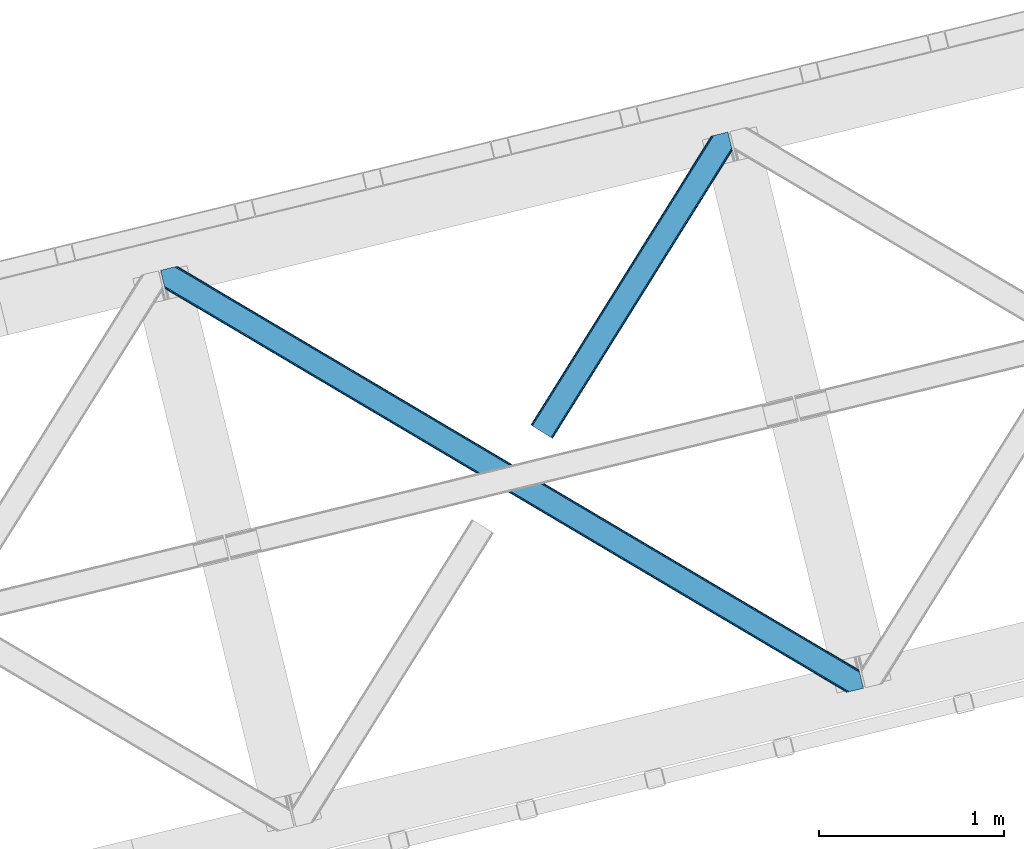
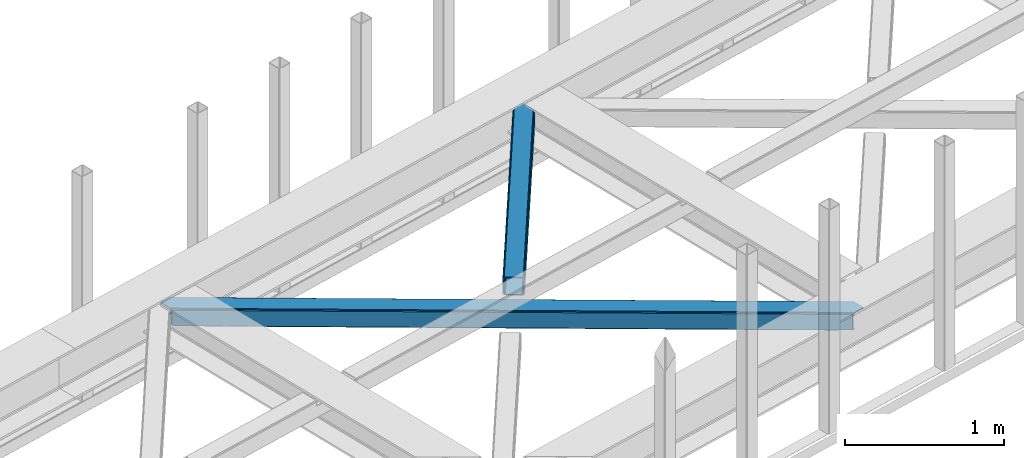
# One storey, part 45 of 66: 2 members.
"""IFC4 building model written with IfcOpenShell, lengths in millimetres."""

from ifc_helpers import new_model, entity, si_unit, converted_unit, derived_unit, direction, frame, origin, place, context, subcontext, project, spatial, triangles, type_object, element, save


model = new_model("IFC4")

# Units and contexts
model_context = context("Model", 3, precision=0.01, world=origin(), true_north=direction((6.12303176911189e-17, 1.0)))
plan_context = context("Plan", 3, precision=0.01, world=origin(), true_north=direction((6.12303176911189e-17, 1.0)))
body_context = subcontext(model_context, "Body", "Model", "MODEL_VIEW")
ifc_project = project(units=[si_unit("LENGTHUNIT", "METRE", prefix="MILLI"), si_unit("AREAUNIT", "SQUARE_METRE"), si_unit("VOLUMEUNIT", "CUBIC_METRE"), converted_unit("PLANEANGLEUNIT", "DEGREE", entity("IfcRatioMeasure", 0.0174532925199433), si_unit("PLANEANGLEUNIT", "RADIAN"), dimensions=[0, 0, 0, 0, 0, 0, 0]), si_unit("MASSUNIT", "GRAM", prefix="KILO"), derived_unit("MASSDENSITYUNIT", [(si_unit("MASSUNIT", "GRAM", prefix="KILO"), 1), (si_unit("LENGTHUNIT", "METRE"), -3)]), derived_unit("MOMENTOFINERTIAUNIT", [(si_unit("LENGTHUNIT", "METRE"), 4)]), si_unit("TIMEUNIT", "SECOND"), si_unit("FREQUENCYUNIT", "HERTZ"), si_unit("THERMODYNAMICTEMPERATUREUNIT", "DEGREE_CELSIUS"), derived_unit("THERMALTRANSMITTANCEUNIT", [(si_unit("MASSUNIT", "GRAM", prefix="KILO"), 1), (si_unit("THERMODYNAMICTEMPERATUREUNIT", "KELVIN"), -1), (si_unit("TIMEUNIT", "SECOND"), -3)]), derived_unit("VOLUMETRICFLOWRATEUNIT", [(si_unit("LENGTHUNIT", "METRE"), 3), (si_unit("TIMEUNIT", "SECOND"), -1)]), derived_unit("MASSFLOWRATEUNIT", [(si_unit("MASSUNIT", "GRAM", prefix="KILO"), 1), (si_unit("TIMEUNIT", "SECOND"), -1)]), derived_unit("ROTATIONALFREQUENCYUNIT", [(si_unit("TIMEUNIT", "SECOND"), -1)]), si_unit("ELECTRICCURRENTUNIT", "AMPERE"), si_unit("ELECTRICVOLTAGEUNIT", "VOLT"), si_unit("POWERUNIT", "WATT"), si_unit("FORCEUNIT", "NEWTON", prefix="KILO"), si_unit("ILLUMINANCEUNIT", "LUX"), si_unit("LUMINOUSFLUXUNIT", "LUMEN"), si_unit("LUMINOUSINTENSITYUNIT", "CANDELA"), derived_unit("USERDEFINED", [(si_unit("MASSUNIT", "GRAM", prefix="KILO"), -1), (si_unit("LENGTHUNIT", "METRE"), -2), (si_unit("TIMEUNIT", "SECOND"), 3), (si_unit("LUMINOUSFLUXUNIT", "LUMEN"), 1)]), derived_unit("LINEARVELOCITYUNIT", [(si_unit("LENGTHUNIT", "METRE"), 1), (si_unit("TIMEUNIT", "SECOND"), -1)]), si_unit("PRESSUREUNIT", "PASCAL"), derived_unit("USERDEFINED", [(si_unit("LENGTHUNIT", "METRE"), -2), (si_unit("MASSUNIT", "GRAM", prefix="KILO"), 1), (si_unit("TIMEUNIT", "SECOND"), -2)]), derived_unit("LINEARFORCEUNIT", [(si_unit("MASSUNIT", "GRAM", prefix="KILO"), 1), (si_unit("LENGTHUNIT", "METRE"), 1), (si_unit("TIMEUNIT", "SECOND"), -2), (si_unit("LENGTHUNIT", "METRE"), -1)]), derived_unit("PLANARFORCEUNIT", [(si_unit("MASSUNIT", "GRAM", prefix="KILO"), 1), (si_unit("LENGTHUNIT", "METRE"), 1), (si_unit("TIMEUNIT", "SECOND"), -2), (si_unit("LENGTHUNIT", "METRE"), -2)])], contexts=[model_context, plan_context])

# Site, building, storey
site_placement = place(None, origin())
site = spatial("IfcSite", under=ifc_project, at=site_placement, CompositionType="ELEMENT")
building_placement = place(site_placement, origin())
building = spatial("IfcBuilding", under=site, at=building_placement, CompositionType="ELEMENT")
storey_placement = place(building_placement, frame((0.0, 0.0, 19800.0)))
storey = spatial("IfcBuildingStorey", under=building, at=storey_placement, Name="06", CompositionType="ELEMENT", Elevation=19800.0)

# Members
member_type_1 = type_object("IfcMemberType", PredefinedType="BRACE")
member_1_placement = place(storey_placement, frame((-18949.85, 14772.6, 3823.0)))
element("IfcMember", 1, at=member_1_placement, inside=storey, type_object=member_type_1, ObjectType="Steel Horizontal Brace", PredefinedType="BRACE", context=body_context, shape_type="Tessellation", body=[
    triangles([(933.016305541994, 1535.69114685059, 0.0), (967.77581176758, 1393.09054870606, 0.0), (14.8444427490249, 64.8692962646492, 0.0), (103.913424682618, 9.26687622070313, 0.0), (928.799121093751, 1552.99009094238, 5.49966430664063), (928.938647460938, 1552.41570739746, 5.208984375), (930.798999023438, 1544.78594055176, 1.33247680664135), (971.99299621582, 1375.79160461426, 5.49966430664063), (971.852307128906, 1376.36715087891, 5.208984375), (969.993118286133, 1383.99575500488, 1.33247680664135), (972.208099365234, 1375.53813171387, 5.8531311035149), (972.418551635743, 1375.28233337402, 6.20659790039281), (928.911904907229, 1553.56912536621, 5.74383544921875), (972.720858764649, 1375.53696899414, 6.35310058593677), (929.027014160158, 1554.17606506348, 5.9996337890625), (973.022003173828, 1375.79160461426, 6.49960327148438), (929.142123413087, 1554.78300476074, 6.25543212890625), (929.250256347656, 1555.36203918457, 6.49960327148438), (4.34740905761646, 71.4223846435561, 5.12526855468968), (1.13016357422021, 73.4315643310547, 10.8039916992202), (973.355703735353, 1630.84231567383, 10.8039916992202), (976.91130065918, 1631.70854187012, 6.49960327148438), (9.16455688476708, 68.4167541503921, 1.33247680664135), (971.503491210937, 1630.3900177002, 17.5012573242202), (0.0, 74.1373352050796, 17.5012573242202), (1081.09680175781, 1548.91592102051, 6.49960327148438), (1056.20297241211, 1651.03759460449, 6.49960327148438), (971.503491210937, 1630.3900177002, 122.499499511719), (0.0, 74.1373352050796, 122.499499511719), (973.355703735353, 1630.84231567383, 129.196765136719), (1.13016357422021, 73.4315643310547, 129.196765136719), (978.633288574219, 1632.12828369141, 134.87548828125), (4.34740905761646, 71.4223846435561, 134.87548828125), (986.526992797852, 1634.05258483887, 138.668280029298), (9.16455688476708, 68.4167541503921, 138.668280029298), (995.835726928712, 1636.32221374512, 140.00075683594), (14.8444427490249, 64.8692962646492, 140.00075683594), (118.757867431643, 0.0, 17.5012573242202), (117.62886657715, 0.705770874024893, 10.8039916992202), (1085.13725280762, 1551.24949951172, 10.9783996582046), (1087.41153259277, 1552.56337280274, 13.4991760253906), (109.594473266603, 5.7205810546875, 1.33247680664135), (114.410458374023, 2.71495056152344, 5.12526855468968), (1087.56501159668, 1551.93434143066, 17.5012573242202), (1081.77234191895, 1575.70149536133, 140.00075683594), (1063.00372009277, 1652.69447021484, 140.00075683594), (103.913424682618, 9.26687622070313, 140.00075683594), (1083.9896484375, 1566.60553894043, 138.668280029298), (109.594473266603, 5.7205810546875, 138.668280029298), (1085.86860351562, 1558.8955444336, 134.87548828125), (114.410458374023, 2.71495056152344, 134.87548828125), (1087.12434082031, 1553.7435333252, 129.196765136719), (117.62886657715, 0.705770874024893, 129.196765136719), (1087.56501159668, 1551.93434143066, 122.499499511719), (118.757867431643, 0.0, 122.499499511719), (1082.5362487793, 1566.77297058106, 12.1248413085959), (1083.96058044434, 1566.72297363281, 13.4991760253906), (1077.84700012207, 1569.98440246582, 8.3320495605476), (1074.64603271485, 1577.50138549805, 6.99957275390625), (1056.69131469727, 1651.1561920166, 6.99957275390625), (1005.56885375977, 1638.69416198731, 6.99957275390625), (20.7789642333992, 61.1625457763676, 6.99957275390625), (97.9742523193381, 12.9736267089847, 6.99957275390625), (108.471286010743, 6.42053833007958, 12.1248413085959), (111.689694213866, 4.41252136230469, 17.8035644531265), (1084.80704040527, 1563.24992980957, 17.8035644531265), (103.65530090332, 9.42733154296911, 8.3320495605476), (1085.24771118164, 1561.44073791504, 24.5008300781265), (112.818695068359, 3.70675048828161, 24.5008300781265), (983.088830566408, 1633.21426391602, 17.8035644531265), (981.235455322265, 1632.76312866211, 24.5008300781265), (7.06468505859448, 69.7236511230476, 17.8035644531265), (5.93568420410156, 70.4294219970707, 24.5008300781265), (988.366415405275, 1634.50139465332, 12.1248413085959), (10.283093261718, 67.7144714355472, 12.1248413085959), (996.260119628907, 1636.42569580078, 8.3320495605476), (15.0990783691414, 64.7088409423832, 8.3320495605476), (981.235455322265, 1632.76312866211, 115.499926757813), (5.93568420410156, 70.4294219970707, 115.499926757813), (996.260119628907, 1636.42569580078, 131.668707275392), (1005.56885375977, 1638.69416198731, 133.001184082033), (1063.00372009277, 1652.69447021484, 133.001184082033), (988.366415405275, 1634.50139465332, 127.873590087893), (983.088830566408, 1633.21426391602, 122.197192382813), (20.7789642333992, 61.1625457763676, 133.001184082033), (15.0990783691414, 64.7088409423832, 131.668707275392), (10.283093261718, 67.7144714355472, 127.873590087893), (7.06468505859448, 69.7236511230476, 122.197192382813), (108.471286010743, 6.42053833007958, 127.873590087893), (111.689694213866, 4.41252136230469, 122.197192382813), (112.818695068359, 3.70675048828161, 115.499926757813), (97.9742523193381, 12.9736267089847, 133.001184082033), (103.65530090332, 9.42733154296911, 131.668707275392), (1085.24771118164, 1561.44073791504, 115.499926757813), (1084.80704040527, 1563.24992980957, 122.197192382813), (1083.55130310059, 1568.40194091797, 127.873590087893), (1081.67118530273, 1576.11309814453, 131.668707275392), (1079.45504150391, 1585.2078918457, 133.001184082033)], [[1, 2, 3], [4, 3, 2], [1, 5, 2], [6, 5, 1], [1, 7, 6], [2, 5, 8], [8, 9, 2], [10, 2, 9], [11, 8, 5], [12, 11, 13], [14, 12, 15], [16, 14, 17], [17, 18, 16], [15, 17, 14], [13, 15, 12], [5, 13, 11], [17, 19, 18], [19, 17, 15], [13, 19, 15], [19, 13, 5], [5, 6, 19], [20, 21, 18], [18, 19, 20], [21, 22, 18], [19, 6, 7], [7, 1, 23], [3, 23, 1], [7, 23, 19], [24, 21, 20], [20, 25, 24], [18, 26, 16], [26, 18, 22], [27, 26, 22], [28, 24, 25], [25, 29, 28], [30, 28, 31], [29, 31, 28], [32, 30, 33], [31, 33, 30], [34, 32, 35], [33, 35, 32], [36, 34, 37], [35, 37, 34], [38, 39, 40], [40, 41, 38], [42, 10, 9], [39, 12, 16], [16, 40, 39], [16, 26, 40], [9, 39, 43], [9, 12, 39], [9, 43, 42], [2, 10, 4], [42, 4, 10], [41, 44, 38], [45, 36, 37], [36, 45, 46], [37, 47, 45], [48, 45, 47], [47, 49, 48], [50, 48, 49], [49, 51, 50], [52, 50, 51], [51, 53, 52], [54, 52, 53], [53, 55, 54], [44, 54, 38], [55, 38, 54], [56, 40, 26], [41, 40, 56], [56, 57, 41], [58, 26, 59], [26, 58, 56], [60, 59, 26], [59, 61, 62], [61, 59, 60], [62, 63, 59], [64, 65, 66], [66, 57, 64], [58, 59, 63], [63, 67, 58], [56, 58, 67], [67, 64, 56], [57, 56, 64], [68, 66, 65], [65, 69, 68], [70, 71, 72], [73, 72, 71], [74, 70, 75], [72, 75, 70], [76, 74, 77], [75, 77, 74], [61, 76, 62], [77, 62, 76], [71, 78, 79], [79, 73, 71], [34, 36, 80], [46, 81, 36], [81, 46, 82], [81, 80, 36], [83, 34, 80], [83, 32, 34], [32, 84, 30], [84, 32, 83], [28, 84, 78], [84, 28, 30], [61, 22, 76], [70, 74, 22], [74, 76, 22], [61, 60, 22], [71, 70, 24], [21, 24, 70], [28, 71, 24], [71, 28, 78], [70, 22, 21], [80, 81, 85], [85, 86, 80], [83, 80, 86], [86, 87, 83], [84, 83, 87], [87, 88, 84], [78, 84, 88], [88, 79, 78], [53, 89, 90], [91, 38, 55], [53, 90, 55], [53, 51, 89], [90, 91, 55], [89, 51, 49], [92, 47, 37], [47, 93, 49], [93, 47, 92], [93, 89, 49], [39, 64, 43], [69, 38, 91], [38, 65, 39], [65, 38, 69], [39, 65, 64], [4, 63, 3], [42, 43, 64], [64, 67, 42], [67, 63, 4], [4, 42, 67], [87, 35, 33], [37, 85, 92], [37, 86, 85], [86, 37, 35], [87, 86, 35], [79, 29, 25], [31, 88, 87], [33, 31, 87], [88, 31, 29], [79, 88, 29], [23, 75, 19], [3, 63, 62], [62, 77, 3], [77, 75, 23], [23, 3, 77], [20, 19, 75], [25, 73, 79], [72, 25, 20], [25, 72, 73], [72, 20, 75], [66, 41, 57], [54, 44, 68], [44, 66, 68], [68, 94, 54], [44, 41, 66], [95, 54, 94], [52, 54, 95], [50, 95, 96], [95, 50, 52], [96, 48, 50], [97, 48, 96], [97, 98, 45], [97, 45, 48], [98, 46, 45], [98, 82, 46], [81, 98, 85], [81, 82, 98], [92, 85, 98], [95, 94, 90], [91, 90, 94], [96, 95, 89], [90, 89, 95], [97, 96, 93], [89, 93, 96], [98, 97, 92], [93, 92, 97], [94, 68, 69], [69, 91, 94]]),
])
member_type_2 = type_object("IfcMemberType", PredefinedType="BRACE")
member_2_placement = place(storey_placement, frame((-20945.29, 13404.29, 3823.0)))
element("IfcMember", 2, at=member_2_placement, inside=storey, type_object=member_type_2, ObjectType="Steel Horizontal Brace", PredefinedType="BRACE", context=body_context, shape_type="Tessellation", body=[
    triangles([(3167.12993774414, 476.931353759765, 17.5012573242202), (3764.84694213867, 123.064581298828, 122.499499511719), (3764.84694213867, 123.064581298828, 17.5012573242202), (2547.33753662109, 843.863607788086, 17.5012573242202), (1927.54397277832, 1210.79469909668, 17.5012573242202), (91.5013916015632, 2297.77602539063, 122.499499511719), (687.960333251955, 1944.65920715332, 17.5012573242202), (91.5013916015632, 2297.77602539063, 17.5012573242202), (1307.752734375, 1577.726953125, 17.5012573242202), (3770.64077453613, 99.2985900878903, 140.00075683594), (3768.42346801758, 108.393383789062, 138.668280029298), (76.4813781738267, 2294.11462097168, 138.668280029298), (67.167993164061, 2291.84499206543, 140.00075683594), (3766.54451293945, 116.103378295898, 134.87548828125), (84.376245117186, 2296.03892211914, 134.87548828125), (3765.28877563477, 121.255389404296, 129.196765136719), (89.6480163574233, 2297.32489013672, 129.196765136719), (3722.24024047852, 5.93103332519422, 140.00075683594), (18.7686218261733, 2198.47743530274, 140.00075683594), (3789.40823364258, 22.3044525146488, 140.00075683594), (0.0, 2275.47157287598, 140.00075683594), (3697.90800476074, 0.0, 122.499499511719), (3699.76021728515, 0.451135253906614, 129.196765136719), (24.1217834472664, 2176.52063598633, 129.196765136719), (24.5612915039055, 2174.7114440918, 122.499499511719), (3705.03780212402, 1.73826599121094, 134.87548828125), (22.8660461425789, 2181.67264709473, 134.87548828125), (3712.93150634766, 3.66256713867188, 138.668280029298), (20.9847656249985, 2189.38264160156, 138.668280029298), (1862.08285217285, 1086.85342712402, 17.5012573242202), (2481.94152832031, 719.882803344726, 17.5012573242202), (3101.8013671875, 352.913342285156, 17.5012573242202), (3697.90800476074, 0.0, 17.5012573242202), (1242.2288269043, 1453.82521362305, 17.5012573242202), (622.368988037109, 1820.79467468262, 17.5012573242202), (24.5612915039055, 2174.7114440918, 17.5012573242202), (74.641955566407, 2293.66697387695, 127.873590087893), (66.7494140624985, 2291.74267272949, 131.668707275392), (79.9160522460952, 2294.9517791748, 122.197192382813), (57.4360290527329, 2289.47188110352, 133.001184082033), (0.0, 2275.47157287598, 133.001184082033), (81.7694274902351, 2295.40291442871, 115.499926757813), (81.7694274902351, 2295.40291442871, 24.5008300781265), (79.9160522460952, 2294.9517791748, 17.8035644531265), (89.5619750976548, 2297.30396118164, 10.8156188964858), (89.473608398439, 2297.28186950684, 10.4993591308594), (74.1140808105483, 2293.53791198731, 12.4271484375022), (72.0351379394524, 2293.03096618652, 10.4993591308594), (1922.19197387695, 1205.8275604248, 24.5008300781265), (3767.16424255371, 113.558184814452, 115.499926757813), (2545.11209106445, 837.046582031249, 24.5008300781265), (3168.02639465332, 468.263278198241, 24.5008300781265), (3767.16424255371, 113.558184814452, 24.5008300781265), (1299.27883300781, 1574.60970153809, 24.5008300781265), (676.358715820312, 1943.39067993164, 24.5008300781265), (3767.6060760498, 111.748992919922, 122.197192382813), (3768.86181335449, 106.596981811523, 127.873590087893), (3770.74076843262, 98.8869873046879, 131.668707275392), (3772.95807495117, 89.7910308837891, 133.001184082033), (3767.69444274902, 111.385061645507, 17.8686767578147), (3767.80141296387, 110.943228149414, 16.5199218750022), (3764.85624389648, 123.027374267578, 16.5199218750022), (3789.40823364258, 22.3044525146488, 133.001184082033), (3731.97336730957, 8.30414428710901, 133.001184082033), (16.4501586914048, 2207.98499450684, 133.001184082033), (162.736578369142, 2253.90544738769, 10.4993591308594), (166.88748779297, 2236.87625427246, 10.4993591308594), (3722.66463317871, 6.03451538085938, 131.668707275392), (18.6686279296882, 2198.88903808594, 131.668707275392), (3714.77092895508, 4.11021423339844, 127.873590087893), (20.547583007814, 2191.1790435791, 127.873590087893), (3709.49334411621, 2.82424621581958, 122.197192382813), (21.8033203125015, 2186.0270324707, 122.197192382813), (3707.6411315918, 2.37311096191297, 115.499926757813), (22.2451538085952, 2184.21784057617, 115.499926757813), (3114.18665771484, 353.713293457031, 24.5008300781265), (3707.6411315918, 2.37311096191297, 24.5008300781265), (2491.12120056152, 722.583801269531, 24.5008300781265), (1868.05458068848, 1091.45547180176, 24.5008300781265), (621.920178222656, 1829.19648742676, 24.5008300781265), (22.2451538085952, 2184.21784057617, 24.5008300781265), (1244.98447265625, 1460.32481689453, 24.5008300781265), (3709.49334411621, 2.82424621581958, 17.8035644531265), (3700.13577575684, 0.542990112304324, 10.8691040039084), (3700.58691101074, 0.653448486327761, 9.52034912109593), (3714.77092895508, 4.11021423339844, 12.1248413085959), (3719.39390258789, 5.23805236816406, 9.52034912109593), (21.7823913574211, 2186.11191101074, 17.817517089843), (21.7614624023445, 2186.20260314941, 17.5012573242202), (32.1398986816421, 2171.84766540527, 10.8179443359368), (28.3471069335938, 2188.73965759277, 10.4993591308594), (27.0146301269524, 2187.35253295898, 12.1248413085959), (32.4980163574219, 2171.71046447754, 10.4993591308594), (203.966619873048, 2084.76925964356, 10.4993591308594), (208.117529296876, 2067.74006652832, 10.4993591308594), (164.09696044922, 2252.5485534668, 9.49942016601563), (168.582733154297, 2234.14502563477, 9.49942016601563), (168.166479492189, 2234.81824035645, 9.74591674804833), (163.769073486328, 2252.87527770996, 9.74126586914281), (167.738598632812, 2235.51122131348, 9.9993896484375), (163.420257568359, 2253.22758178711, 9.9993896484375), (167.306066894533, 2236.20303955078, 10.2528625488303), (163.066790771485, 2253.5775604248, 10.2598388671868), (209.163977050783, 2067.67262878418, 9.49942016601563), (209.136071777342, 2067.46799011231, 9.88311767578125), (204.682855224608, 2085.44363708496, 9.8528869628899), (208.803533935548, 2067.55635681152, 10.0831054687515), (204.682855224608, 2084.81228027344, 10.2063537597678), (208.45006713867, 2067.6516998291, 10.2993713378928), (204.324737548828, 2084.79018859863, 10.3528564453118), (204.678204345702, 2086.07499389648, 9.49942016601563), (3763.57957763672, 109.728186035156, 12.1248413085959), (3758.57058105469, 124.97144165039, 10.8714294433594), (3757.06485900879, 125.435366821288, 9.52034912109593), (3761.54365539551, 107.0643951416, 9.52034912109593), (3585.92414245605, 211.034793090819, 9.52034912109593), (3581.44534606934, 229.405764770507, 9.52034912109593), (3585.50672607422, 211.134786987304, 9.44360961914208), (3581.0453704834, 229.553430175782, 9.37384643554833), (3580.64655761719, 229.701095581055, 9.22734375000073), (3580.53842468262, 229.533663940429, 8.87387695312646), (3585.45672912598, 210.476687622069, 9.13897705078125), (3580.42680358887, 229.365069580077, 8.52041015625218), (3585.40440673828, 209.805798339843, 8.82736816406396), (3585.35440979004, 209.14769897461, 8.52041015625218), (3164.51846923828, 472.521157836914, 5.12526855468968), (3581.30233154297, 225.771102905273, 5.12526855468968), (3166.45090942383, 475.784912109375, 10.8039916992202), (687.281304931639, 1943.51276550293, 10.8039916992202), (685.348864746094, 1940.24901123047, 5.12526855468968), (165.152709960938, 2248.21625976562, 5.12526855468968), (682.456018066405, 1935.36326293945, 1.33247680664135), (167.033990478514, 2240.50510253906, 1.33247680664135), (679.044598388671, 1929.60082397461, 0.0), (169.250134277343, 2231.41030883789, 0.0), (3583.18128662109, 218.061108398437, 1.33247680664135), (3585.39859313965, 208.966314697265, 0.0), (3158.21536560059, 461.872970581055, 0.0), (3161.62562255859, 467.635409545897, 1.33247680664135), (2546.65850830078, 842.717166137694, 10.8039916992202), (1926.86610717774, 1209.64942016602, 10.8039916992202), (1307.07370605469, 1576.58051147461, 10.8039916992202), (2544.72606811523, 839.452249145508, 5.12526855468968), (1924.93366699219, 1206.38450317383, 5.12526855468968), (1305.14126586914, 1573.31675720215, 5.12526855468968), (2541.83322143555, 834.567663574218, 1.33247680664135), (1922.0408203125, 1201.49875488281, 1.33247680664135), (1302.24841918945, 1568.43100891113, 1.33247680664135), (2538.42296447754, 828.804061889648, 0.0), (1918.63056335449, 1195.73631591797, 0.0), (1298.83699951172, 1562.66856994629, 0.0), (3620.15926208496, 66.3657165527347, 0.0), (3110.71477661133, 367.971725463867, 0.0), (2490.85610046387, 734.942349243163, 0.0), (1871.00091247559, 1101.91297302246, 0.0), (631.282397460938, 1835.85305786133, 0.0), (1251.14223632812, 1468.88359680176, 0.0), (204.010803222656, 2088.80971069336, 0.0), (3167.34852905274, 467.117999267577, 17.8035644531265), (3165.41492614746, 463.853082275391, 12.1248413085959), (673.747247314452, 1938.98048400879, 12.1248413085959), (675.6796875, 1942.24540100098, 17.8035644531265), (670.854400634766, 1934.09473571777, 8.3320495605476), (169.398962402345, 2230.8022064209, 8.81806640624927), (171.566271972657, 2221.90391235351, 6.99957275390625), (3159.11182250977, 453.204895019531, 6.99957275390625), (3587.71589355469, 199.458755493164, 6.99957275390625), (3585.50672607422, 208.524481201172, 8.42274169921802), (3162.5232421875, 458.967333984374, 8.3320495605476), (667.442980957032, 1928.33229675293, 6.99957275390625), (2539.60777587891, 827.750637817382, 8.3320495605476), (2536.1975189209, 821.987036132812, 6.99957275390625), (1916.68882141113, 1196.53161621094, 8.3320495605476), (1913.2774017334, 1190.76917724609, 6.99957275390625), (1290.36309814453, 1559.55131835938, 6.99957275390625), (1293.77451782226, 1565.31375732422, 8.3320495605476), (2542.50062255859, 832.635223388672, 12.1248413085959), (1919.58166809082, 1201.41736450195, 12.1248413085959), (1296.66736450195, 1570.19950561523, 12.1248413085959), (2544.43306274414, 835.90014038086, 17.8035644531265), (1921.51410827637, 1204.68111877441, 17.8035644531265), (1298.5998046875, 1573.4632598877, 17.8035644531265), (201.692340087891, 2098.31726989746, 6.99957275390625), (203.861975097658, 2089.41781311035, 8.81806640624927), (206.226947021485, 2079.71491699219, 1.33247680664135), (208.105902099611, 2072.00492248535, 5.12526855468968), (2500.03460998535, 737.643347167968, 6.99957275390625), (3123.1012298584, 368.771676635743, 6.99957275390625), (1876.96915283203, 1106.51385498047, 6.99957275390625), (3617.84196166992, 75.8721130371086, 6.99957275390625), (630.833587646484, 1844.25487060547, 6.99957275390625), (1253.90020751953, 1475.38320007324, 6.99957275390625), (3119.68981018067, 363.009237670898, 8.3320495605476), (3620.5638885498, 65.041378784179, 8.90410766601781), (3620.20344543457, 66.183169555663, 8.52041015625218), (3116.79696350098, 358.123489379883, 12.1248413085959), (3621.05455627442, 64.3216552734375, 9.1087463378899), (3621.55336303711, 63.5937927246086, 9.31571044922021), (3622.03937988281, 62.8729064941399, 9.52034912109593), (3620.05112915039, 66.8075500488285, 8.42274169921802), (624.529321289061, 1833.60668334961, 12.1248413085959), (627.422167968751, 1838.49243164063, 8.3320495605476), (622.596881103516, 1830.34176635742, 17.8035644531265), (3114.86452331543, 354.859735107422, 17.8035644531265), (2491.79906616211, 723.730242919921, 17.8035644531265), (1868.73360900879, 1092.60075073242, 17.8035644531265), (1245.66350097656, 1461.47125854492, 17.8035644531265), (2493.73150634766, 726.995159912109, 12.1248413085959), (1870.66604919434, 1095.86566772461, 12.1248413085959), (1247.59594116211, 1464.73617553711, 12.1248413085959), (2496.62435302734, 731.879745483398, 8.3320495605476), (1873.55889587402, 1100.75141601562, 8.3320495605476), (1250.4887878418, 1469.6207611084, 8.3320495605476), (3102.47923278809, 354.059783935547, 10.8039916992202), (624.980456542969, 1825.20487060547, 5.12526855468968), (623.04569091797, 1821.94111633301, 10.8039916992202), (3626.51817626953, 44.5019348144524, 9.52034912109593), (3104.41167297363, 357.323538208007, 5.12526855468968), (3624.25552368164, 49.5597656249993, 5.12526855468968), (3625.13105163574, 45.9669616699211, 8.52041015625218), (3625.82752075195, 45.2344482421868, 9.02037963867406), (3622.37656860351, 57.2709228515614, 1.33247680664135), (3107.30451965332, 362.209286499023, 1.33247680664135), (627.870977783205, 1830.09061889648, 1.33247680664135), (2487.44468078613, 729.179910278321, 1.33247680664135), (1867.58600463867, 1096.14937133789, 1.33247680664135), (1247.73081665039, 1463.12115783691, 1.33247680664135), (2484.55299682617, 724.294161987304, 5.12526855468968), (1864.69315795898, 1091.26362304687, 5.12526855468968), (1244.8379699707, 1458.2354095459, 5.12526855468968), (2482.6193939209, 721.029244995118, 10.8039916992202), (1862.76536865234, 1088.00103149414, 10.8039916992202), (1242.90552978516, 1454.97049255371, 10.8039916992202)], [[1, 2, 3], [2, 1, 4], [2, 5, 6], [5, 2, 4], [7, 8, 6], [9, 6, 5], [6, 9, 7], [10, 11, 12], [12, 13, 10], [11, 14, 15], [15, 12, 11], [14, 16, 17], [17, 15, 14], [16, 2, 6], [6, 17, 16], [18, 10, 19], [18, 20, 10], [13, 19, 10], [21, 19, 13], [22, 23, 24], [24, 25, 22], [23, 26, 27], [27, 24, 23], [26, 28, 29], [29, 27, 26], [28, 18, 19], [19, 29, 28], [30, 22, 25], [22, 31, 32], [30, 31, 22], [32, 33, 22], [34, 25, 35], [25, 34, 30], [36, 35, 25], [37, 38, 12], [15, 37, 12], [15, 17, 39], [37, 15, 39], [39, 17, 6], [38, 13, 12], [21, 40, 41], [21, 13, 40], [38, 40, 13], [39, 6, 42], [43, 8, 44], [6, 43, 42], [8, 45, 44], [6, 8, 43], [46, 44, 45], [46, 47, 44], [46, 48, 47], [49, 50, 42], [50, 51, 52], [49, 51, 50], [52, 53, 50], [54, 42, 55], [42, 54, 49], [43, 55, 42], [50, 56, 42], [39, 42, 56], [56, 57, 39], [37, 39, 57], [57, 58, 37], [38, 37, 58], [58, 59, 38], [40, 38, 59], [57, 14, 11], [59, 58, 10], [58, 57, 11], [60, 61, 62], [63, 59, 20], [10, 20, 59], [58, 11, 10], [60, 3, 53], [2, 50, 53], [53, 3, 2], [60, 62, 3], [2, 56, 50], [56, 14, 57], [14, 56, 16], [2, 16, 56], [59, 64, 65], [64, 59, 63], [65, 40, 59], [41, 40, 65], [66, 67, 46], [48, 46, 67], [64, 68, 65], [69, 65, 68], [68, 70, 69], [71, 69, 70], [70, 72, 71], [73, 71, 72], [72, 74, 73], [75, 73, 74], [76, 74, 77], [74, 76, 78], [74, 79, 75], [79, 74, 78], [80, 81, 75], [82, 75, 79], [75, 82, 80], [70, 68, 28], [26, 70, 28], [26, 23, 72], [70, 26, 72], [72, 23, 22], [68, 18, 28], [20, 64, 63], [20, 18, 64], [68, 64, 18], [72, 22, 74], [77, 33, 83], [22, 77, 74], [33, 84, 83], [22, 33, 77], [85, 83, 84], [86, 83, 85], [87, 86, 85], [73, 75, 25], [25, 24, 73], [27, 73, 24], [73, 27, 71], [25, 81, 36], [88, 89, 36], [36, 81, 88], [75, 81, 25], [69, 29, 19], [21, 65, 19], [41, 65, 21], [69, 71, 29], [29, 71, 27], [65, 69, 19], [90, 91, 92], [90, 93, 91], [92, 36, 90], [89, 36, 92], [94, 95, 93], [93, 91, 94], [96, 97, 98], [98, 99, 96], [99, 98, 100], [100, 101, 99], [101, 100, 102], [102, 103, 101], [103, 102, 67], [67, 66, 103], [104, 105, 106], [105, 107, 108], [108, 107, 109], [110, 109, 95], [95, 94, 110], [109, 110, 108], [108, 106, 105], [106, 111, 104], [62, 112, 113], [112, 62, 61], [112, 114, 113], [112, 115, 114], [114, 115, 116], [116, 117, 114], [118, 119, 117], [120, 119, 118], [121, 120, 122], [123, 121, 124], [124, 125, 123], [122, 124, 121], [118, 122, 120], [117, 116, 118], [1, 3, 113], [3, 62, 113], [120, 121, 126], [123, 126, 121], [123, 127, 126], [128, 113, 117], [117, 126, 128], [117, 119, 126], [120, 126, 119], [113, 114, 117], [45, 129, 66], [129, 130, 131], [131, 96, 129], [129, 99, 101], [99, 129, 96], [129, 103, 66], [103, 129, 101], [129, 45, 8], [8, 7, 129], [66, 46, 45], [130, 132, 133], [133, 131, 130], [132, 134, 135], [135, 133, 132], [136, 137, 138], [138, 139, 136], [127, 136, 139], [139, 126, 127], [113, 128, 1], [1, 128, 4], [140, 4, 128], [4, 140, 5], [141, 5, 140], [5, 141, 9], [142, 9, 141], [9, 142, 7], [129, 7, 142], [128, 126, 143], [143, 140, 128], [140, 143, 144], [144, 141, 140], [141, 144, 145], [145, 142, 141], [142, 145, 129], [130, 129, 145], [126, 139, 146], [146, 143, 126], [143, 146, 144], [147, 144, 146], [144, 147, 145], [148, 145, 147], [145, 148, 132], [132, 130, 145], [139, 138, 146], [149, 146, 138], [146, 149, 147], [150, 147, 149], [147, 150, 151], [151, 148, 147], [148, 151, 132], [134, 132, 151], [137, 152, 153], [138, 153, 154], [153, 138, 137], [149, 155, 150], [154, 149, 138], [149, 154, 155], [156, 134, 151], [150, 157, 151], [157, 150, 155], [157, 156, 151], [158, 134, 156], [135, 134, 158], [159, 160, 112], [112, 61, 159], [159, 60, 53], [161, 162, 44], [98, 163, 100], [98, 97, 163], [163, 102, 100], [163, 67, 102], [97, 164, 163], [161, 47, 67], [67, 163, 161], [47, 48, 67], [163, 164, 165], [166, 167, 168], [160, 118, 116], [116, 112, 160], [116, 115, 112], [169, 168, 125], [125, 160, 169], [124, 122, 160], [122, 118, 160], [160, 125, 124], [168, 169, 166], [165, 170, 163], [44, 47, 161], [162, 55, 43], [43, 44, 162], [53, 52, 159], [61, 60, 159], [166, 169, 171], [171, 172, 166], [172, 171, 173], [173, 174, 172], [174, 173, 175], [176, 175, 173], [175, 176, 170], [163, 170, 176], [169, 160, 171], [177, 171, 160], [171, 177, 178], [178, 173, 171], [173, 178, 179], [179, 176, 173], [176, 179, 161], [161, 163, 176], [160, 159, 180], [180, 177, 160], [177, 180, 181], [181, 178, 177], [178, 181, 179], [182, 179, 181], [179, 182, 161], [162, 161, 182], [159, 52, 180], [51, 180, 52], [180, 51, 49], [49, 181, 180], [181, 49, 54], [54, 182, 181], [182, 54, 55], [55, 162, 182], [97, 131, 133], [135, 97, 133], [165, 164, 135], [165, 135, 183], [131, 97, 96], [135, 164, 97], [183, 158, 184], [158, 185, 111], [158, 183, 135], [186, 111, 185], [158, 111, 184], [186, 104, 111], [187, 188, 166], [166, 172, 187], [172, 189, 187], [189, 172, 174], [188, 167, 166], [188, 190, 167], [170, 191, 175], [191, 170, 183], [165, 183, 170], [192, 175, 191], [174, 192, 189], [175, 192, 174], [193, 194, 195], [196, 197, 194], [196, 198, 197], [196, 199, 198], [194, 193, 196], [195, 200, 193], [86, 87, 199], [199, 196, 86], [193, 200, 190], [191, 183, 184], [201, 108, 110], [110, 94, 201], [94, 92, 201], [94, 91, 92], [202, 106, 108], [202, 111, 106], [202, 184, 111], [108, 201, 202], [203, 201, 92], [92, 89, 203], [203, 88, 81], [81, 80, 203], [89, 88, 203], [184, 202, 191], [190, 188, 193], [83, 86, 196], [196, 204, 83], [77, 83, 204], [204, 76, 77], [76, 204, 205], [205, 78, 76], [78, 205, 206], [206, 79, 78], [79, 206, 207], [207, 82, 79], [82, 207, 80], [203, 80, 207], [204, 196, 205], [208, 205, 196], [205, 208, 206], [209, 206, 208], [206, 209, 207], [210, 207, 209], [207, 210, 201], [201, 203, 207], [196, 193, 211], [211, 208, 196], [208, 211, 212], [212, 209, 208], [209, 212, 213], [213, 210, 209], [210, 213, 202], [202, 201, 210], [193, 188, 211], [187, 211, 188], [211, 187, 212], [189, 212, 187], [212, 189, 213], [192, 213, 189], [213, 192, 202], [191, 202, 192], [214, 84, 33], [35, 36, 90], [215, 105, 104], [216, 90, 95], [95, 215, 216], [95, 107, 215], [104, 186, 215], [84, 214, 217], [214, 218, 219], [219, 220, 214], [221, 217, 214], [214, 220, 221], [217, 85, 84], [222, 219, 218], [218, 223, 222], [152, 222, 223], [223, 153, 152], [156, 224, 185], [185, 158, 156], [224, 215, 186], [186, 185, 224], [90, 216, 35], [33, 32, 214], [153, 223, 154], [225, 154, 223], [154, 225, 155], [226, 155, 225], [155, 226, 157], [227, 157, 226], [157, 227, 224], [224, 156, 157], [223, 218, 228], [228, 225, 223], [225, 228, 229], [229, 226, 225], [226, 229, 230], [230, 227, 226], [227, 230, 224], [215, 224, 230], [218, 214, 231], [231, 228, 218], [228, 231, 229], [232, 229, 231], [229, 232, 230], [233, 230, 232], [230, 233, 215], [216, 215, 233], [214, 32, 231], [31, 231, 32], [231, 31, 30], [30, 232, 231], [232, 30, 34], [34, 233, 232], [233, 34, 216], [35, 216, 34], [137, 167, 190], [125, 127, 123], [137, 125, 167], [125, 136, 127], [125, 137, 136], [152, 137, 190], [195, 152, 190], [219, 195, 220], [195, 222, 152], [195, 219, 222], [220, 195, 194], [221, 194, 197], [221, 197, 198], [217, 198, 199], [87, 85, 199], [217, 199, 85]]),
])

save(model, "model.ifc")
